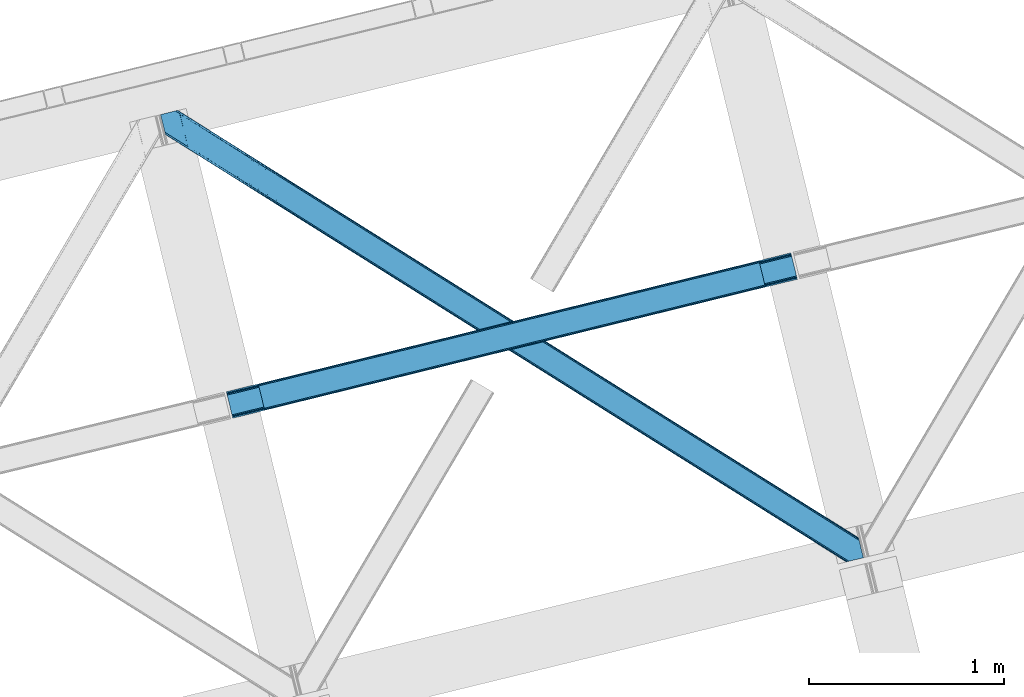
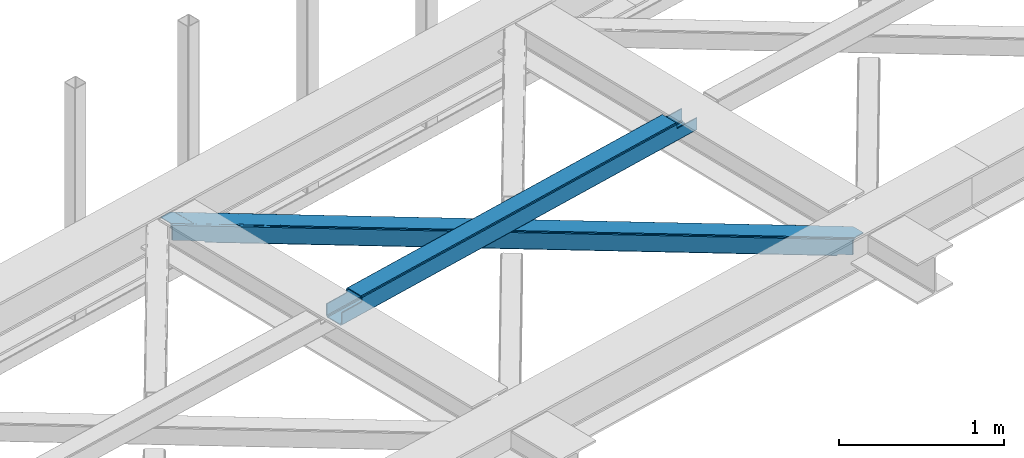
# One storey, part 22 of 66: 1 beam, 1 member.
"""IFC4 building model written with IfcOpenShell, lengths in millimetres."""

from ifc_helpers import new_model, entity, si_unit, converted_unit, derived_unit, direction, frame, origin, place, context, subcontext, project, spatial, triangles, polygons, material, type_object, element, save


model = new_model("IFC4")

# Units and contexts
model_context = context("Model", 3, precision=0.01, world=origin(), true_north=direction((6.12303176911189e-17, 1.0)))
plan_context = context("Plan", 3, precision=0.01, world=origin(), true_north=direction((6.12303176911189e-17, 1.0)))
body_context = subcontext(model_context, "Body", "Model", "MODEL_VIEW")
ifc_project = project(units=[si_unit("LENGTHUNIT", "METRE", prefix="MILLI"), si_unit("AREAUNIT", "SQUARE_METRE"), si_unit("VOLUMEUNIT", "CUBIC_METRE"), converted_unit("PLANEANGLEUNIT", "DEGREE", entity("IfcRatioMeasure", 0.0174532925199433), si_unit("PLANEANGLEUNIT", "RADIAN"), dimensions=[0, 0, 0, 0, 0, 0, 0]), si_unit("MASSUNIT", "GRAM", prefix="KILO"), derived_unit("MASSDENSITYUNIT", [(si_unit("MASSUNIT", "GRAM", prefix="KILO"), 1), (si_unit("LENGTHUNIT", "METRE"), -3)]), derived_unit("MOMENTOFINERTIAUNIT", [(si_unit("LENGTHUNIT", "METRE"), 4)]), si_unit("TIMEUNIT", "SECOND"), si_unit("FREQUENCYUNIT", "HERTZ"), si_unit("THERMODYNAMICTEMPERATUREUNIT", "DEGREE_CELSIUS"), derived_unit("THERMALTRANSMITTANCEUNIT", [(si_unit("MASSUNIT", "GRAM", prefix="KILO"), 1), (si_unit("THERMODYNAMICTEMPERATUREUNIT", "KELVIN"), -1), (si_unit("TIMEUNIT", "SECOND"), -3)]), derived_unit("VOLUMETRICFLOWRATEUNIT", [(si_unit("LENGTHUNIT", "METRE"), 3), (si_unit("TIMEUNIT", "SECOND"), -1)]), derived_unit("MASSFLOWRATEUNIT", [(si_unit("MASSUNIT", "GRAM", prefix="KILO"), 1), (si_unit("TIMEUNIT", "SECOND"), -1)]), derived_unit("ROTATIONALFREQUENCYUNIT", [(si_unit("TIMEUNIT", "SECOND"), -1)]), si_unit("ELECTRICCURRENTUNIT", "AMPERE"), si_unit("ELECTRICVOLTAGEUNIT", "VOLT"), si_unit("POWERUNIT", "WATT"), si_unit("FORCEUNIT", "NEWTON", prefix="KILO"), si_unit("ILLUMINANCEUNIT", "LUX"), si_unit("LUMINOUSFLUXUNIT", "LUMEN"), si_unit("LUMINOUSINTENSITYUNIT", "CANDELA"), derived_unit("USERDEFINED", [(si_unit("MASSUNIT", "GRAM", prefix="KILO"), -1), (si_unit("LENGTHUNIT", "METRE"), -2), (si_unit("TIMEUNIT", "SECOND"), 3), (si_unit("LUMINOUSFLUXUNIT", "LUMEN"), 1)]), derived_unit("LINEARVELOCITYUNIT", [(si_unit("LENGTHUNIT", "METRE"), 1), (si_unit("TIMEUNIT", "SECOND"), -1)]), si_unit("PRESSUREUNIT", "PASCAL"), derived_unit("USERDEFINED", [(si_unit("LENGTHUNIT", "METRE"), -2), (si_unit("MASSUNIT", "GRAM", prefix="KILO"), 1), (si_unit("TIMEUNIT", "SECOND"), -2)]), derived_unit("LINEARFORCEUNIT", [(si_unit("MASSUNIT", "GRAM", prefix="KILO"), 1), (si_unit("LENGTHUNIT", "METRE"), 1), (si_unit("TIMEUNIT", "SECOND"), -2), (si_unit("LENGTHUNIT", "METRE"), -1)]), derived_unit("PLANARFORCEUNIT", [(si_unit("MASSUNIT", "GRAM", prefix="KILO"), 1), (si_unit("LENGTHUNIT", "METRE"), 1), (si_unit("TIMEUNIT", "SECOND"), -2), (si_unit("LENGTHUNIT", "METRE"), -2)])], contexts=[model_context, plan_context])

# Site, building, storey
site_placement = place(None, origin())
site = spatial("IfcSite", under=ifc_project, at=site_placement, CompositionType="ELEMENT")
building_placement = place(site_placement, origin())
building = spatial("IfcBuilding", under=site, at=building_placement, CompositionType="ELEMENT")
storey_placement = place(building_placement, frame((0.0, 0.0, 19800.0)))
storey = spatial("IfcBuildingStorey", under=building, at=storey_placement, Name="06", CompositionType="ELEMENT", Elevation=19800.0)

# Beam
ifc_material = material(Name="Metal painted (White)")
beam_type = type_object("IfcBeamType", PredefinedType="BEAM")
beam_placement = place(storey_placement, frame((-54824.16, 5769.04, 3967.02)))
element("IfcBeam", 1, at=beam_placement, inside=storey, type_object=beam_type, material=ifc_material, ObjectType="Steel Beam", PredefinedType="BEAM", context=body_context, shape_type="Tessellation", body=[
    polygons([(195.600194800813, 47.1939241264222, 116.42075398189), (195.284716026293, 48.4881398473771, 123.117713426564), (2768.48559452429, 681.870165407988, 122.252244531349), (2768.8010732988, 680.575949687039, 115.555285086674), (194.386308486354, 52.1737543987821, 128.795119546125), (2767.58718698436, 685.555779959382, 127.92965065091), (193.041746584857, 57.68966637537, 132.588638724685), (2766.24262508285, 691.071691935976, 131.723169829474), (191.455727682833, 64.1961281805606, 133.920742055655), (2764.65660618083, 697.578153741184, 133.055273160444), (169.904498669375, 152.607589262092, 133.920675186106), (2743.10537716737, 785.989614822718, 133.055206290887), (168.318479767342, 159.11405106732, 132.588562012879), (2741.51935826533, 792.496076627927, 131.723093117668), (166.973917865845, 164.62996304391, 128.795034490451), (2740.17479636384, 798.011988604516, 127.92956559524), (166.075510325905, 168.315577595309, 123.117622795697), (2739.2763888239, 801.697603155919, 122.25215390049), (165.760031551394, 169.609793316236, 116.420661393285), (2738.9609100494, 802.991818876856, 115.55519249807), (2737.3031232022, 809.792700498515, 100.498086491912), (2737.3031232022, 809.792700498512, 122.555187727575), (2737.61860197673, 808.498484777561, 129.252149129995), (2738.51700951666, 804.812870226159, 134.929560824745), (2739.86157141815, 799.296958249569, 138.723088347173), (2741.44759032019, 792.790496444372, 140.055201520396), (2766.31439302802, 690.777272119526, 140.055278677568), (2767.90041193007, 684.270810314297, 138.723175346603), (2769.24497383155, 678.754898337704, 134.929656168038), (2770.14338137148, 675.069283786305, 129.252250048477), (2770.45886014632, 673.775068064077, 122.555290603803), (2770.458860146, 673.775068065387, 100.498086491912), (2768.8010732988, 680.575949687043, 100.498086491912), (2738.9609100494, 802.991818876859, 100.498086491912), (165.760031551394, 169.609793316234, 101.477862600484), (195.600194800804, 47.19392412642, 101.477862600484), (197.257981650611, 40.3930424941034, 101.477862600484), (197.257981647995, 40.3930425047642, 123.420759499018), (196.942502873484, 41.6872582257018, 130.117718943693), (196.044095333544, 45.3728727771036, 135.795125063254), (194.699533432056, 50.8887847536925, 139.588644241814), (193.113514530023, 57.3952465589037, 140.920747572779), (168.246711822184, 159.408470883749, 140.920670415607), (166.660692920151, 165.91493268896, 139.588557242389), (165.316131018655, 171.430844665549, 135.795029719961), (164.417723478715, 175.116459216949, 130.117618025206), (164.102244704213, 176.410674937892, 123.420656622786), (164.102244704204, 176.410674937891, 101.477862600484), (2932.90331800302, 720.968992071854, 99.4980864919168), (2932.90331800301, 720.968992071855, 24.5000861794985), (31.4979500966005, 6.80088174161364, 25.4759431828536), (31.4979500966005, 6.80088174161039, 100.477862600484), (194.629175601386, 46.954912041303, 100.477862600484), (1.65778684719041, 129.216750931428, 25.4758505942489), (2903.0631547536, 843.38486126167, 24.4999935908851), (2903.06315475361, 843.384861261669, 99.4980864919168), (2739.93192924883, 803.230830961977, 99.4980864919125), (1.65778684719041, 129.216750931425, 100.477862600484), (2934.56110484841, 714.168110457476, 17.5000909499932), (2934.56110485024, 714.168110450053, 99.4980864919168), (2771.42987934576, 674.014080149109, 99.4980864919125), (33.1557369624336, 4.30807858720073e-08, 100.477862600484), (33.1557369474987, 1.04891924479489e-07, 18.4759479533483), (2901.40536790643, 850.185742883325, 99.4980864919125), (2901.40536790642, 850.185742883325, 17.4999880737653), (-8.66293703438714e-12, 136.017632553082, 18.4758450771204), (-8.66293703438714e-12, 136.017632553081, 100.477862600484), (163.131225504786, 176.171662852774, 100.477862600484), (2769.77209249823, 680.814961772162, 99.4980864919168), (2738.27414240164, 810.031712583632, 99.4980864919125), (2903.37863352811, 842.090645540732, 17.8030341462194), (2904.27704106805, 838.405030989331, 12.125628026654), (2905.62160296955, 832.88911901274, 8.33210884809829), (2907.20762187157, 826.382657207531, 7.00000551712847), (2928.75885088503, 737.971196125998, 7.00007238668162), (2930.34486978706, 731.464734320788, 8.33218555990442), (2931.68943168856, 725.948822344197, 12.1257130823282), (2932.5878392285, 722.263207792796, 17.8031247770826), (2934.24562607568, 715.46232617116, 10.8031295475774), (2933.34721853574, 719.147940722563, 5.12571785282298), (2932.00265663425, 724.663852699151, 1.33219033039485), (2930.41663773223, 731.170314504341, 7.715717638348e-05), (2905.54983502439, 833.183538829187, 4.33146851719357e-12), (2903.96381612235, 839.690000634412, 1.33210333096982), (2902.61925422086, 845.205912611001, 5.12562250952989), (2901.72084668092, 848.891527162403, 10.8030286290909), (196.286962448568, 40.1540304196461, 100.477862600484), (164.789012351976, 169.370781231118, 100.477862600484), (27.3534829786202, 23.8030857957542, 7.97592939004109), (28.9395018806444, 17.2966239905647, 9.30804256325955), (30.2840637821412, 11.7807120139757, 13.1015700856834), (31.1824713220808, 8.09509746257289, 18.7789817804377), (1.97326562169287, 127.922535210498, 18.7788911495702), (2.87167316163245, 124.236920659101, 13.1014850300135), (4.21623506312922, 118.72100868251, 9.30796585145342), (5.80225396516212, 112.214546877286, 7.9758625204836), (0.315478774519784, 134.723416832145, 11.7788856324504), (1.21388631445936, 131.037802280743, 6.10147951288935), (2.5584482159388, 125.521890304153, 2.30796033432496), (4.1444671179717, 119.015428498944, 0.975857003359465), (29.0112698258106, 17.0022041740973, 0.975934160527186), (30.5972887278435, 10.4957423688883, 2.30804733374998), (31.9418506293316, 4.97983039229717, 6.10157485618245), (32.8402581692712, 1.2942158408987, 11.7789865509282)], [[[1, 2, 3, 4]], [[2, 5, 6, 3]], [[5, 7, 8, 6]], [[7, 9, 10, 8]], [[11, 12, 10, 9]], [[11, 13, 14, 12]], [[13, 15, 16, 14]], [[15, 17, 18, 16]], [[17, 19, 20, 18]], [[21, 22, 23, 24, 25, 26, 27, 28, 29, 30, 31, 32, 33, 4, 3, 6, 8, 10, 12, 14, 16, 18, 20, 34]], [[35, 19, 17, 15, 13, 11, 9, 7, 5, 2, 1, 36, 37, 38, 39, 40, 41, 42, 43, 44, 45, 46, 47, 48]], [[42, 41, 28, 27]], [[41, 40, 29, 28]], [[40, 39, 30, 29]], [[39, 38, 31, 30]], [[27, 26, 43, 42]], [[47, 46, 23, 22]], [[46, 45, 24, 23]], [[45, 44, 25, 24]], [[44, 43, 26, 25]], [[33, 49, 50, 51, 52, 53, 1, 4]], [[54, 55, 56, 57, 20, 19, 35, 58]], [[59, 60, 61, 31, 38, 37, 62, 63]], [[64, 65, 66, 67, 68, 47, 22, 21]], [[61, 60, 49, 69]], [[64, 70, 57, 56]], [[65, 64, 56, 55, 71, 72, 73, 74, 75, 76, 77, 78, 50, 49, 60, 59, 79, 80, 81, 82, 83, 84, 85, 86]], [[87, 53, 52, 62]], [[67, 58, 88, 68]], [[89, 90, 76, 75]], [[90, 91, 77, 76]], [[91, 92, 78, 77]], [[92, 51, 50, 78]], [[54, 93, 71, 55]], [[93, 94, 72, 71]], [[94, 95, 73, 72]], [[95, 96, 74, 73]], [[89, 75, 74, 96]], [[66, 97, 98, 99, 100, 101, 102, 103, 104, 63, 62, 52, 51, 92, 91, 90, 89, 96, 95, 94, 93, 54, 58, 67]], [[63, 104, 79, 59]], [[104, 103, 80, 79]], [[103, 102, 81, 80]], [[102, 101, 82, 81]], [[100, 99, 84, 83]], [[99, 98, 85, 84]], [[98, 97, 86, 85]], [[97, 66, 65, 86]], [[83, 82, 101, 100]]], closed=False),
])

# Member
member_type = type_object("IfcMemberType", PredefinedType="BRACE")
member_placement = place(storey_placement, frame((-55162.19, 5030.3, 3824.0)))
element("IfcMember", 2, at=member_placement, inside=storey, type_object=member_type, ObjectType="Steel Horizontal Brace", PredefinedType="BRACE", context=body_context, shape_type="Tessellation", body=[
    triangles([(207.722204589845, 2101.81647491455, 0.0), (172.045312499999, 2248.17905273438, 0.0), (3404.49451904296, 219.293591308594, 0.0), (3440.17141113281, 72.9304321289064, 0.0), (202.587634277341, 2097.1307144165, 1.33247680664135), (208.512854003908, 2098.5748123169, 0.155804443358647), (3442.44569091796, 63.5955368041996, 1.33247680664135), (3445.6640991211, 50.3934356689451, 10.8039916992202), (3446.115234375, 48.5365722656252, 17.5012573242202), (187.951318359374, 2093.56290893555, 17.5012573242202), (189.755859375, 2094.00299835205, 10.8039916992202), (3444.37580566406, 55.6814849853517, 5.12526855468968), (194.895080566406, 2095.25582885742, 5.12526855468968), (3405.09448242188, 238.005821228027, 10.8039916992202), (3400.22036132812, 236.818684387207, 5.32758178711083), (167.840917968751, 2265.42858123779, 5.12526855468968), (166.547973632813, 2270.71604919434, 10.8039916992202), (3400.29942626953, 236.497773742676, 5.1694519042976), (3402.2155883789, 228.628486633301, 1.33247680664135), (169.766381835936, 2257.51452941895, 1.33247680664135), (3406.8990234375, 238.445910644531, 17.5012573242202), (166.096838378908, 2272.57291259766, 17.5012573242202), (3401.19239501953, 237.055297851563, 18.5197998046897), (3406.8990234375, 238.445910644531, 18.5197998046897), (3400.50406494141, 236.887866210937, 18.2267944335945), (3400.82032470703, 236.964605712891, 18.4453857421868), (3400.29477539063, 236.836706542969, 17.9035583496116), (3400.22036132812, 236.818684387207, 17.5198608398459), (3402.04350585937, 231.951539611817, 18.4453857421868), (3401.8388671875, 231.936424255371, 18.1454040527351), (3401.62027587891, 231.920146179199, 17.8198425292976), (3401.61097412109, 231.919564819336, 17.8058898925774), (3401.42028808594, 231.905612182617, 17.5198608398459), (3402.49929199219, 231.698648071289, 18.5197998046897), (3586.90198974609, 125.462690734864, 18.5197998046897), (3589.64135742188, 114.236631774903, 18.5197998046897), (204.382873535156, 2097.56789703369, 12.1248413085959), (208.512854003908, 2098.5748123169, 9.69243164062573), (199.652929687501, 2096.41506042481, 17.9802978515618), (198.425097656247, 2096.11624145508, 19.5011352539077), (187.951318359374, 2093.56290893555, 19.5011352539077), (25.310083007811, 2195.64679412842, 19.5011352539077), (22.6823364257798, 2206.42171783447, 19.5011352539077), (3437.79016113281, 82.6879760742186, 6.99957275390625), (3404.59683837891, 218.870942687989, 8.3320495605476), (3402.66672363281, 226.784994506836, 12.1248413085959), (3406.87111816406, 209.536047363282, 6.99957275390625), (3443.24564208985, 60.3184112548834, 17.5198608398459), (3441.99920654297, 65.4390289306639, 12.1248413085959), (3446.115234375, 48.5365722656252, 17.5198608398459), (3440.06909179688, 73.3530807495117, 8.3320495605476), (1232.86428222656, 1574.07891998291, 6.99957275390625), (640.588806152344, 1945.82774047852, 6.99957275390625), (602.805065917964, 1862.1026184082, 6.99957275390625), (1195.07589111328, 1490.35496063232, 6.99957275390625), (1825.13975830078, 1202.32951812744, 6.99957275390625), (1787.3513671875, 1118.60788421631, 6.99957275390625), (205.340954589839, 2111.57401885986, 6.99957275390625), (174.421911621095, 2238.42150878906, 6.99957275390625), (2971.89766845703, 375.113150024415, 6.99957275390625), (3009.69071044922, 458.831295776367, 6.99957275390625), (2379.62219238281, 746.860807800294, 6.99957275390625), (2417.415234375, 830.580697631836, 6.99957275390625), (168.836206054686, 2261.33697052002, 18.501196289064), (166.096838378908, 2272.57291259766, 18.501196289064), (168.971081542964, 2260.78584136963, 17.8803039550803), (170.217517089841, 2255.67045593262, 12.1248413085959), (172.147631835935, 2247.75698547363, 8.3320495605476), (207.559423828126, 2102.47631835938, 8.8831787109375), (3444.59439697266, 58.9998870849613, 18.5197998046897), (3447.33376464844, 47.7738281250004, 18.5197998046897), (3447.04541015625, 47.9546310424803, 18.2849304199226), (3444.26883544922, 59.317890930176, 18.2802795410171), (3446.72449951171, 48.1552001953123, 18.0198303222678), (3443.92001953125, 59.6591491699219, 18.0198303222678), (3446.40358886719, 48.356350708008, 17.757055664064), (3443.63166503906, 59.9422714233397, 17.8058898925774), (3443.57120361328, 60.0009887695314, 17.7617065429695), (3534.35635986328, 2.65972137451172, 18.5197998046897), (3523.44539794922, 0.0, 18.5197998046897), (2962.59125976562, 360.290798950195, 24.5008300781265), (2963.30284423828, 361.419218444825, 17.8035644531265), (3532.92854003906, 2.31206817626935, 24.5008300781265), (2965.31667480469, 364.63239440918, 12.1248413085959), (596.224072265621, 1851.62186279297, 12.1248413085959), (599.242492675781, 1856.43029022217, 8.3320495605476), (594.21024169922, 1848.40868682861, 17.8035644531265), (593.498657226563, 1847.28026733398, 24.5008300781265), (22.9334838867144, 2205.40433807373, 24.5008300781265), (2968.33509521484, 369.440821838379, 8.3320495605476), (2370.32043457031, 732.038456726074, 24.5008300781265), (2371.02736816406, 733.16629486084, 17.8035644531265), (1778.75654296875, 1104.91395263672, 17.8035644531265), (1778.0449584961, 1103.78553314209, 24.5008300781265), (1186.48106689453, 1476.6616104126, 17.8035644531265), (1185.77413330078, 1475.53319091797, 24.5008300781265), (2373.04584960937, 736.379470825195, 12.1248413085959), (1780.77037353515, 1108.12712860107, 12.1248413085959), (1188.49954833985, 1479.87420501709, 12.1248413085959), (2376.06427001953, 741.188479614258, 8.3320495605476), (1783.78879394531, 1112.93555603027, 8.3320495605476), (1191.51796875, 1484.68321380615, 8.3320495605476), (2965.14924316406, 350.42105255127, 122.499499511719), (2371.32502441406, 723.143650817871, 122.499499511719), (3523.44539794922, 0.0, 122.499499511719), (1777.49615478516, 1095.86624908447, 122.499499511719), (1183.67193603516, 1468.58884735107, 122.499499511719), (589.843066406247, 1841.31144561768, 122.499499511719), (25.310083007811, 2195.64679412842, 122.499499511719), (3532.92854003906, 2.31206817626935, 115.499926757813), (22.9334838867144, 2205.40433807373, 115.499926757813), (3534.73308105468, 2.75215759277398, 122.197192382813), (22.4776977539077, 2207.26120147705, 122.197192382813), (3539.876953125, 4.00498809814508, 127.873590087893), (21.1894042968706, 2212.54925079346, 127.873590087893), (3547.56485595703, 5.87987365722711, 131.668707275392), (19.2592895507769, 2220.4633026123, 131.668707275392), (3556.63872070312, 8.09194793701226, 133.001184082033), (16.9850097656235, 2229.79819793701, 133.001184082033), (3525.24993896484, 0.440089416503724, 129.196765136719), (3530.38916015625, 1.69291992187482, 134.87548828125), (3547.15557861328, 5.77987976074201, 140.00075683594), (3612.21207275391, 21.6376327514654, 140.00075683594), (3612.21207275391, 21.6376327514654, 133.001184082033), (3538.08171386718, 3.56780548095685, 138.668280029298), (168.515295410158, 2261.63113861084, 18.7407165527366), (165.808483886714, 2272.75313415527, 18.7360656738274), (168.171130371091, 2261.94914245605, 19.0011657714858), (165.492224121095, 2272.95428466797, 19.0011657714858), (167.826965332031, 2262.26714630127, 19.2592895507805), (165.17131347656, 2273.15543518066, 19.2639404296897), (167.510705566405, 2262.56131439209, 19.5011352539077), (164.882958984374, 2273.33565673828, 19.5011352539077), (78.2975463867188, 2318.55673370361, 19.5011352539077), (88.7666748046831, 2321.11006622314, 19.5011352539077), (649.183630371095, 1959.52167205811, 17.8035644531265), (3018.28553466796, 472.525227355957, 17.8035644531265), (3016.26705322265, 469.312632751465, 12.1248413085959), (3018.99246826172, 473.653646850586, 24.5008300781265), (3589.2832397461, 115.705146789551, 24.5008300781265), (649.890563964844, 1960.65009155273, 24.5008300781265), (79.2835327148423, 2318.79799804688, 24.5008300781265), (3013.2486328125, 464.503623962402, 8.3320495605476), (644.146728515625, 1951.50006866455, 8.3320495605476), (647.165148925778, 1956.30849609375, 12.1248413085959), (2420.97315673828, 836.253025817871, 8.3320495605476), (1828.69768066406, 1208.00184631348, 8.3320495605476), (1236.42220458984, 1579.75124816895, 8.3320495605476), (2423.99157714844, 841.061453247071, 12.1248413085959), (1831.71610107422, 1212.81027374268, 12.1248413085959), (1239.440625, 1584.55967559815, 12.1248413085959), (2426.01005859375, 844.274629211426, 17.8035644531265), (1833.73458251953, 1216.02344970703, 17.8035644531265), (1241.45910644531, 1587.7728515625, 17.8035644531265), (2426.7169921875, 845.403048706055, 24.5008300781265), (1834.44151611328, 1217.15186920166, 24.5008300781265), (1242.16604003906, 1588.90068969727, 24.5008300781265), (1247.70988769531, 1593.6864440918, 122.499499511719), (653.815905761716, 1966.45090026855, 122.499499511719), (1841.59921875, 1220.9225692749, 122.499499511719), (3586.90198974609, 125.462690734864, 122.499499511719), (2435.4932006836, 848.158694458008, 122.499499511719), (3029.38718261719, 475.394819641114, 122.499499511719), (88.7666748046831, 2321.11006622314, 122.499499511719), (3591.02266845703, 108.560234069824, 127.873590087893), (3588.64606933593, 118.317778015137, 134.87548828125), (3590.57618408203, 110.403726196289, 138.668280029298), (3592.95278320312, 100.646182250976, 131.668707275392), (3595.22706298828, 91.3112869262695, 133.001184082033), (3592.85046386719, 101.068830871583, 140.00075683594), (3589.734375, 113.848283386231, 122.197192382813), (3587.3577758789, 123.605827331543, 129.196765136719), (3589.2832397461, 115.705146789551, 115.499926757813), (55.5733520507783, 2313.01811828613, 133.001184082033), (0.0, 2299.47185211182, 133.001184082033), (79.2835327148423, 2318.79799804688, 115.499926757813), (64.647216796875, 2315.23019256592, 131.668707275392), (72.3397705078096, 2317.105078125, 127.873590087893), (77.4789916992158, 2318.35790863037, 122.197192382813), (76.0651245117188, 2318.01316223145, 138.000878906252), (81.8229125976577, 2319.41714630127, 134.87548828125), (86.962133789064, 2320.66997680664, 129.196765136719), (0.0, 2299.47185211182, 138.000878906252), (24.8589477539063, 2197.50365753174, 129.196765136719), (23.5706542968765, 2202.79228820801, 134.87548828125), (22.1242309570298, 2208.71692657471, 138.000878906252), (98.1940063476577, 2304.12389373779, 138.000878906252), (139.391491699214, 2135.11211700439, 138.000878906252), (599.144824218747, 1856.13379669189, 140.00075683594), (139.828674316406, 2137.54627075195, 139.000817871096), (140.051916503908, 2136.3818069458, 138.668280029298), (137.847399902341, 2145.67426300049, 140.00075683594), (592.568481445313, 1845.65304107666, 134.87548828125), (139.805419921875, 2135.02549438477, 138.075292968751), (595.586901855466, 1850.46146850586, 138.668280029298), (139.921691894531, 2135.65975799561, 138.352020263672), (140.037963867188, 2136.29576568604, 138.631072998047), (2974.45565185547, 365.243403625488, 140.00075683594), (2970.89307861328, 359.571075439453, 138.668280029298), (2967.87465820312, 354.762648010254, 134.87548828125), (2965.86082763672, 351.549472045898, 129.196765136719), (590.549999999996, 1842.4398651123, 129.196765136719), (2372.03195800781, 724.272070312501, 129.196765136719), (1778.2030883789, 1096.9946685791, 129.196765136719), (1184.3788696289, 1469.7172668457, 129.196765136719), (2374.05043945312, 727.485246276856, 134.87548828125), (1780.22156982421, 1100.20784454346, 134.87548828125), (1186.39270019531, 1472.93044281006, 134.87548828125), (2377.06885986328, 732.293673706055, 138.668280029298), (1783.23999023438, 1105.01627197266, 138.668280029298), (1189.41112060547, 1477.73887023926, 138.668280029298), (2380.62678222656, 737.96600189209, 140.00075683594), (1786.79791259766, 1110.68860015869, 140.00075683594), (1192.97369384766, 1483.41119842529, 140.00075683594), (651.090490722658, 1962.10930480957, 134.87548828125), (98.7102539062471, 2303.62683105469, 138.075292968751), (99.1985961914033, 2302.47515716553, 138.384576416018), (648.072070312497, 1957.30087738037, 138.668280029298), (99.6032226562456, 2301.53800506592, 138.633398437501), (644.514147949216, 1951.62854919434, 140.00075683594), (100.189233398436, 2300.16483306885, 139.000817871096), (102.170507812501, 2292.03684082031, 140.00075683594), (3028.68024902343, 474.266400146485, 129.196765136719), (3026.66176757812, 471.053224182129, 134.87548828125), (3023.64334716797, 466.24479675293, 138.668280029298), (3020.08542480469, 460.572468566895, 140.00075683594), (653.108972167967, 1965.32248077393, 129.196765136719), (2429.74936523438, 839.008671569824, 138.668280029298), (2426.1914428711, 833.336343383789, 140.00075683594), (1835.86003417968, 1211.77254638672, 138.668280029298), (1832.2974609375, 1206.10021820068, 140.00075683594), (1241.96605224609, 1584.53700256348, 138.668280029298), (1238.40347900391, 1578.86467437744, 140.00075683594), (2432.76778564453, 843.817680358887, 134.87548828125), (1838.87845458985, 1216.58155517578, 134.87548828125), (1244.98447265625, 1589.34542999268, 134.87548828125), (2434.78626708984, 847.030274963379, 129.196765136719), (1840.89228515625, 1219.79473114014, 129.196765136719), (1247.00295410156, 1592.55860595703, 129.196765136719)], [[1, 2, 3], [3, 4, 1], [5, 6, 4], [4, 7, 5], [8, 9, 10], [10, 11, 8], [12, 8, 11], [11, 13, 12], [7, 12, 13], [13, 5, 7], [6, 1, 4], [14, 15, 16], [16, 17, 14], [18, 19, 20], [19, 3, 2], [2, 20, 19], [20, 16, 18], [15, 18, 16], [21, 14, 17], [17, 22, 21], [23, 21, 24], [25, 23, 26], [23, 25, 27], [23, 27, 28], [21, 23, 28], [28, 15, 14], [14, 21, 28], [26, 29, 30], [25, 30, 31], [27, 32, 33], [27, 31, 32], [33, 28, 27], [31, 27, 25], [30, 25, 26], [23, 34, 29], [29, 26, 23], [34, 24, 35], [24, 34, 23], [35, 36, 34], [37, 38, 5], [37, 5, 13], [13, 11, 39], [38, 6, 5], [39, 37, 13], [11, 10, 40], [41, 40, 10], [11, 40, 39], [42, 43, 40], [40, 41, 42], [3, 44, 4], [45, 19, 46], [33, 15, 28], [18, 33, 46], [33, 18, 15], [3, 19, 45], [46, 19, 18], [3, 47, 44], [45, 47, 3], [8, 48, 9], [48, 12, 49], [12, 48, 8], [50, 9, 48], [49, 7, 51], [51, 4, 44], [4, 51, 7], [49, 12, 7], [52, 53, 54], [54, 55, 52], [55, 56, 52], [56, 55, 57], [53, 58, 54], [53, 59, 58], [60, 61, 62], [61, 60, 47], [44, 47, 60], [63, 62, 61], [57, 63, 56], [62, 63, 57], [17, 22, 64], [22, 65, 64], [66, 17, 64], [66, 16, 17], [67, 16, 66], [20, 67, 68], [67, 20, 16], [2, 20, 68], [68, 59, 2], [69, 38, 6], [69, 1, 58], [1, 59, 58], [59, 1, 2], [69, 6, 1], [70, 71, 72], [72, 73, 70], [73, 72, 74], [74, 75, 73], [75, 76, 77], [75, 74, 76], [76, 78, 77], [78, 76, 50], [50, 48, 78], [71, 70, 79], [79, 80, 71], [81, 70, 73], [73, 82, 81], [73, 75, 82], [75, 77, 82], [83, 79, 70], [70, 81, 83], [82, 77, 78], [78, 84, 82], [78, 48, 84], [48, 49, 84], [54, 58, 69], [85, 86, 38], [86, 69, 38], [87, 85, 37], [88, 87, 39], [39, 40, 88], [88, 40, 89], [43, 89, 40], [37, 39, 87], [38, 37, 85], [69, 86, 54], [51, 44, 90], [60, 90, 44], [49, 51, 84], [90, 84, 51], [81, 82, 91], [92, 91, 82], [91, 92, 93], [93, 94, 91], [94, 93, 95], [95, 96, 94], [96, 95, 87], [87, 88, 96], [82, 84, 97], [97, 92, 82], [92, 97, 98], [98, 93, 92], [93, 98, 99], [99, 95, 93], [95, 99, 85], [85, 87, 95], [84, 90, 100], [100, 97, 84], [97, 100, 101], [101, 98, 97], [98, 101, 102], [102, 99, 98], [99, 102, 86], [86, 85, 99], [90, 60, 62], [62, 100, 90], [100, 62, 57], [57, 101, 100], [101, 57, 55], [55, 102, 101], [102, 55, 54], [54, 86, 102], [9, 103, 104], [71, 105, 72], [71, 80, 105], [105, 74, 72], [50, 105, 103], [50, 76, 105], [76, 74, 105], [9, 50, 103], [106, 10, 9], [10, 107, 108], [109, 41, 108], [106, 107, 10], [106, 9, 104], [10, 108, 41], [42, 41, 109], [81, 110, 83], [110, 81, 91], [110, 94, 111], [94, 110, 91], [88, 89, 111], [96, 111, 94], [111, 96, 88], [112, 110, 111], [111, 113, 112], [114, 112, 113], [113, 115, 114], [116, 114, 115], [115, 117, 116], [118, 116, 117], [117, 119, 118], [112, 120, 121], [118, 122, 123], [123, 124, 118], [118, 116, 122], [116, 125, 122], [114, 125, 116], [121, 125, 114], [112, 105, 120], [110, 105, 112], [121, 114, 112], [80, 83, 79], [110, 80, 105], [83, 80, 110], [65, 64, 126], [126, 127, 65], [127, 126, 128], [128, 129, 127], [129, 128, 130], [130, 131, 129], [131, 130, 132], [132, 133, 131], [134, 135, 133], [133, 132, 134], [136, 66, 67], [137, 138, 33], [138, 46, 33], [139, 29, 34], [34, 140, 139], [34, 36, 140], [139, 137, 32], [32, 31, 139], [30, 29, 139], [139, 31, 30], [141, 130, 128], [141, 132, 130], [128, 136, 141], [64, 136, 126], [128, 126, 136], [64, 66, 136], [132, 141, 142], [142, 134, 132], [33, 32, 137], [45, 46, 143], [138, 143, 46], [47, 45, 61], [143, 61, 45], [53, 144, 59], [68, 59, 144], [144, 145, 68], [67, 68, 145], [67, 145, 136], [61, 143, 63], [146, 63, 143], [63, 146, 147], [147, 56, 63], [56, 147, 148], [148, 52, 56], [52, 148, 144], [144, 53, 52], [143, 138, 146], [149, 146, 138], [146, 149, 147], [150, 147, 149], [147, 150, 148], [151, 148, 150], [148, 151, 144], [145, 144, 151], [138, 137, 152], [152, 149, 138], [149, 152, 153], [153, 150, 149], [150, 153, 154], [154, 151, 150], [151, 154, 136], [136, 145, 151], [137, 139, 152], [155, 152, 139], [152, 155, 153], [156, 153, 155], [153, 156, 154], [157, 154, 156], [154, 157, 136], [141, 136, 157], [158, 22, 159], [22, 158, 160], [161, 35, 24], [21, 160, 162], [21, 163, 24], [160, 21, 22], [24, 163, 161], [162, 163, 21], [164, 159, 65], [164, 65, 127], [22, 65, 159], [129, 164, 127], [164, 129, 131], [131, 133, 164], [135, 164, 133], [165, 166, 167], [165, 167, 168], [169, 168, 170], [171, 166, 165], [124, 169, 123], [170, 123, 169], [168, 167, 170], [172, 166, 171], [35, 161, 173], [140, 35, 173], [35, 140, 36], [172, 171, 161], [171, 173, 161], [119, 174, 169], [174, 119, 175], [169, 118, 119], [124, 118, 169], [156, 173, 176], [173, 155, 139], [156, 155, 173], [139, 140, 173], [157, 176, 141], [176, 157, 156], [142, 141, 176], [168, 169, 174], [174, 177, 168], [165, 168, 177], [177, 178, 165], [171, 165, 178], [178, 179, 171], [173, 171, 179], [179, 176, 173], [177, 174, 180], [181, 178, 180], [177, 180, 178], [179, 181, 182], [174, 183, 180], [174, 175, 183], [179, 178, 181], [164, 176, 179], [176, 164, 135], [142, 135, 134], [135, 142, 176], [164, 179, 182], [111, 42, 109], [184, 113, 109], [113, 184, 185], [113, 111, 109], [89, 42, 111], [43, 42, 89], [115, 113, 185], [186, 119, 117], [119, 186, 183], [183, 175, 119], [117, 115, 186], [186, 115, 185], [180, 186, 187], [180, 183, 186], [188, 187, 186], [189, 190, 191], [189, 192, 190], [193, 194, 188], [188, 185, 193], [188, 186, 185], [195, 196, 194], [195, 191, 196], [194, 193, 195], [197, 195, 189], [125, 122, 198], [198, 199, 125], [121, 125, 199], [199, 200, 121], [120, 121, 200], [200, 201, 120], [105, 120, 201], [201, 103, 105], [108, 202, 109], [184, 109, 202], [202, 193, 184], [185, 184, 193], [103, 201, 104], [203, 104, 201], [104, 203, 204], [204, 106, 104], [106, 204, 205], [205, 107, 106], [107, 205, 108], [202, 108, 205], [201, 200, 206], [206, 203, 201], [203, 206, 204], [207, 204, 206], [204, 207, 208], [208, 205, 204], [205, 208, 193], [193, 202, 205], [200, 199, 209], [209, 206, 200], [206, 209, 210], [210, 207, 206], [207, 210, 208], [211, 208, 210], [208, 211, 193], [195, 193, 211], [199, 198, 212], [212, 209, 199], [209, 212, 213], [213, 210, 209], [210, 213, 214], [214, 211, 210], [211, 214, 189], [189, 195, 211], [215, 216, 217], [217, 218, 215], [217, 219, 218], [187, 215, 181], [181, 180, 187], [219, 220, 218], [219, 221, 220], [221, 222, 220], [172, 161, 223], [163, 223, 161], [166, 172, 224], [223, 224, 172], [167, 166, 225], [224, 225, 166], [170, 167, 226], [225, 226, 167], [215, 227, 182], [182, 181, 215], [227, 159, 164], [164, 182, 227], [226, 225, 228], [228, 229, 226], [229, 228, 230], [230, 231, 229], [231, 230, 232], [232, 233, 231], [233, 232, 218], [218, 220, 233], [225, 224, 234], [234, 228, 225], [228, 234, 235], [235, 230, 228], [230, 235, 236], [236, 232, 230], [232, 236, 215], [215, 218, 232], [224, 223, 234], [237, 234, 223], [234, 237, 235], [238, 235, 237], [235, 238, 236], [239, 236, 238], [236, 239, 215], [227, 215, 239], [223, 163, 162], [162, 237, 223], [237, 162, 160], [160, 238, 237], [238, 160, 158], [158, 239, 238], [239, 158, 159], [159, 227, 239], [214, 233, 189], [233, 214, 231], [213, 231, 214], [231, 213, 229], [222, 192, 220], [189, 220, 192], [220, 189, 233], [170, 226, 198], [198, 122, 170], [123, 170, 122], [226, 212, 198], [212, 229, 213], [226, 229, 212], [197, 190, 221], [221, 219, 197], [219, 217, 194], [217, 216, 194], [222, 221, 192], [190, 192, 221]]),
])

save(model, "model.ifc")
